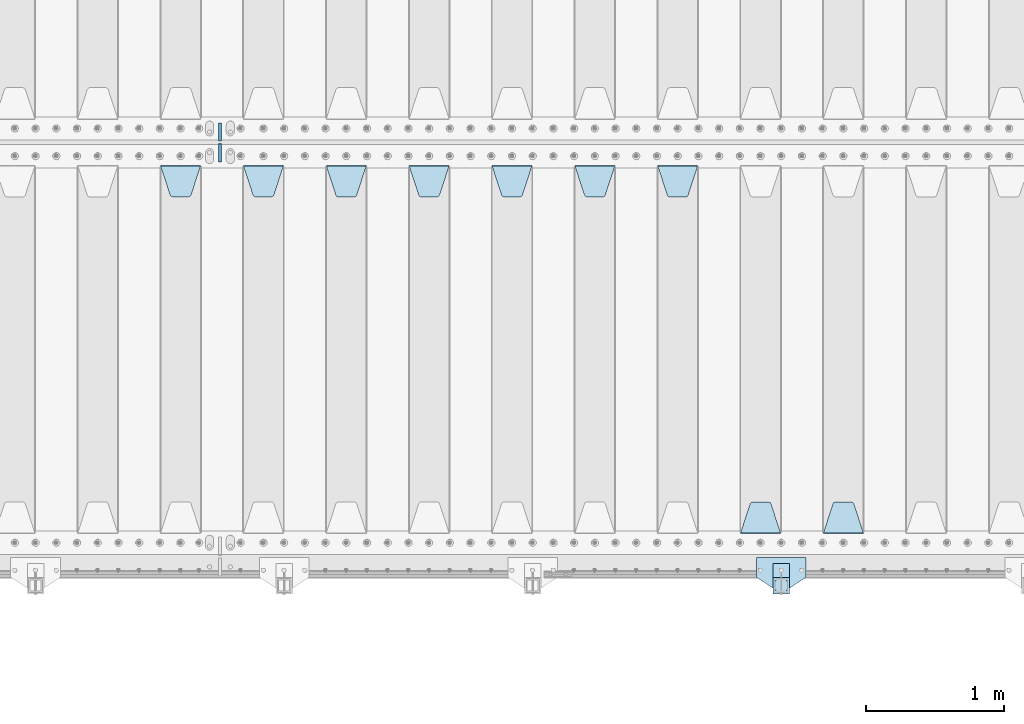
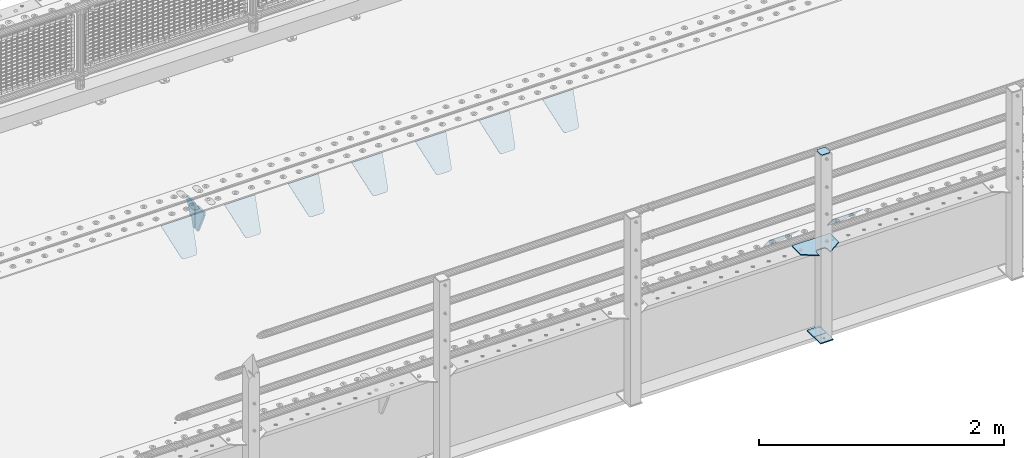
# One storey, part 206 of 242: 15 plates.
"""IFC2X3 building model written with IfcOpenShell, lengths in millimetres."""

import ifcopenshell
import ifcopenshell.guid

model = None  # the IFC model being written
_history = None  # IfcOwnerHistory: only IFC2X3 demands one
_inside = {}  # id of a spatial element -> (the spatial element, [elements in it])
_under = {}  # id of a project, library or spatial element -> (it, [spatial elements below it])
_declared = {}  # id of a project -> (the project, [libraries it declares])
_typed = {}  # id of a type object -> (the type object, [elements of that type])
_made_of = {}  # id of a material, layer set ... -> (it, [elements and type objects made of it])


def new_model(schema):
    """Start an empty IFC model of exactly this schema.

    Asked for "IFC4X3", IfcOpenShell would pick the latest addendum, in which some entities
    have other attributes; the version numbers below select the first issue.
    IFC2X3 requires an IfcOwnerHistory on every rooted entity: one is made here for all.
    """
    global model, _history
    if schema == "IFC4X3":
        model = ifcopenshell.file(schema_version=(4, 3, 0, 0))
    else:
        model = ifcopenshell.file(schema=schema)
    _inside.clear()
    _under.clear()
    _declared.clear()
    _typed.clear()
    _made_of.clear()
    _history = None
    if model.schema == "IFC2X3":
        org = make("IfcOrganization", Name="unknown")
        user = make(
            "IfcPersonAndOrganization",
            ThePerson=make("IfcPerson", FamilyName="unknown"),
            TheOrganization=org,
        )
        app = make(
            "IfcApplication",
            ApplicationDeveloper=org,
            Version="unknown",
            ApplicationFullName="unknown",
            ApplicationIdentifier="unknown",
        )
        _history = make(
            "IfcOwnerHistory",
            OwningUser=user,
            OwningApplication=app,
            ChangeAction="ADDED",
            CreationDate=0,
        )
    return model


def make(cls, **values):
    """One entity of the class cls with the attributes given. An attribute that is None is left unset."""
    return model.create_entity(
        cls, **{name: value for name, value in values.items() if value is not None}
    )


def rooted(cls, **values):
    """An entity with a GlobalId (a new one), such as an element, a storey or a relation."""
    return make(cls, GlobalId=ifcopenshell.guid.new(), OwnerHistory=_history, **values)


def si_unit(unit_type, name, prefix=None):
    """IfcSIUnit, for example si_unit("LENGTHUNIT", "METRE", prefix="MILLI")."""
    return make("IfcSIUnit", UnitType=unit_type, Prefix=prefix, Name=name)


def assignment(units):
    """IfcUnitAssignment: the units of a project."""
    return None if units is None else make("IfcUnitAssignment", Units=units)


def point(xyz):
    """IfcCartesianPoint."""
    return None if xyz is None else make("IfcCartesianPoint", Coordinates=xyz)


def direction(xyz):
    """IfcDirection."""
    return None if xyz is None else make("IfcDirection", DirectionRatios=xyz)


def frame(location, z_axis=None, x_axis=None):
    """IfcAxis2Placement3D, a coordinate frame: its origin and axes. An axis left out is left unset."""
    return make(
        "IfcAxis2Placement3D",
        Location=point(location),
        Axis=direction(z_axis),
        RefDirection=direction(x_axis),
    )


def origin_with_axes():
    """The frame at (0, 0, 0) with the z axis (0, 0, 1) and the x axis (1, 0, 0) written out."""
    return frame((0.0, 0.0, 0.0), z_axis=(0.0, 0.0, 1.0), x_axis=(1.0, 0.0, 0.0))


def place(relative_to, where):
    """IfcLocalPlacement: puts the frame where relative to a parent placement (None: the world)."""
    return make(
        "IfcLocalPlacement", PlacementRelTo=relative_to, RelativePlacement=where
    )


def context(
    kind, dimensions, precision=None, world=None, true_north=None, identifier=None
):
    """IfcGeometricRepresentationContext, for example the 3D "Model" context."""
    return make(
        "IfcGeometricRepresentationContext",
        ContextIdentifier=identifier,
        ContextType=kind,
        CoordinateSpaceDimension=dimensions,
        Precision=precision,
        WorldCoordinateSystem=world,
        TrueNorth=true_north,
    )


def subcontext(parent, identifier, kind, view, scale=None):
    """IfcGeometricRepresentationSubContext, for example "Body" below "Model"."""
    return make(
        "IfcGeometricRepresentationSubContext",
        ContextIdentifier=identifier,
        ContextType=kind,
        ParentContext=parent,
        TargetScale=scale,
        TargetView=view,
    )


def project(units=None, contexts=None):
    """IfcProject with its units and contexts."""
    return rooted(
        "IfcProject",
        Name="project",
        RepresentationContexts=contexts,
        UnitsInContext=assignment(units),
    )


def spatial(cls, under=None, at=None, **own):
    """A site, building, storey or space (cls), placed at a placement, below another one or the project."""
    s = rooted(cls, ObjectPlacement=at, **own)
    if under is not None:
        _under.setdefault(under.id(), (under, []))[1].append(s)
    return s


def faces_of(points, faces, orient=None, outer=None):
    """IfcFace entities. A face is a list of loops; a loop is a list of indices into points, from 0.

    orient and outer hold one flag for each loop. By default every Orientation is true, the
    first loop of a face is its IfcFaceOuterBound and the others are IfcFaceBound.
    """
    made = []
    for i, loops in enumerate(faces):
        bounds = []
        for j, loop in enumerate(loops):
            is_outer = j == 0 if outer is None else outer[i][j]
            bounds.append(
                make(
                    "IfcFaceOuterBound" if is_outer else "IfcFaceBound",
                    Bound=make("IfcPolyLoop", Polygon=[points[k] for k in loop]),
                    Orientation=True if orient is None else orient[i][j],
                )
            )
        made.append(make("IfcFace", Bounds=bounds))
    return made


def faceted_brep(points, faces, orient=None, outer=None, voids=None):
    """IfcFacetedBrep: a solid bounded by flat faces; with voids (closed shells), ...WithVoids."""
    shared = [point(p) for p in points]
    hull = make("IfcClosedShell", CfsFaces=faces_of(shared, faces, orient, outer))
    if voids is None:
        return make("IfcFacetedBrep", Outer=hull)
    return make(
        "IfcFacetedBrepWithVoids",
        Outer=hull,
        Voids=[
            make(cls, CfsFaces=faces_of(shared, fs, o, b)) for cls, fs, o, b in voids
        ],
    )


def shape(context_of_items, identifier, shape_type, items):
    """IfcShapeRepresentation: the items that make up one representation, for example the "Body"."""
    return make(
        "IfcShapeRepresentation",
        ContextOfItems=context_of_items,
        RepresentationIdentifier=identifier,
        RepresentationType=shape_type,
        Items=items,
    )


def material(Name=None, Category=None):
    """IfcMaterial."""
    return make("IfcMaterial", Name=Name, Category=Category)


def made_of(thing, what):
    """Note that an element or type object is made of a material, layer set ...; save() writes the relation."""
    if what is not None:
        _made_of.setdefault(what.id(), (what, []))[1].append(thing)
    return thing


def type_object(cls, material=None, **own):
    """A type object (cls), such as IfcWallType, which elements share."""
    return made_of(rooted(cls, **own), material)


def element(
    cls,
    number,
    at=None,
    inside=None,
    cuts=None,
    type_object=None,
    material=None,
    context=None,
    identifier="Body",
    shape_type=None,
    held_by="IfcProductDefinitionShape",
    body=None,
    shapes=None,
    **own,
):
    """One element of the class cls, such as IfcWall. Its Tag is "e" and its number.

    at: its placement. inside: the storey or other place that contains it. cuts: it is an
    opening in that element (IfcRelVoidsElement). A single representation is given by context,
    identifier, shape_type and body (its items); several are given by shapes. held_by: the class
    of the entity that holds the representations. save() writes the other relations.
    """
    e = rooted(cls, Tag="e%d" % number, ObjectPlacement=at, **own)
    if body is not None:
        shapes = [shape(context, identifier, shape_type, body)]
    if shapes is not None:
        e.Representation = make(held_by, Representations=shapes)
    if inside is not None:
        _inside.setdefault(inside.id(), (inside, []))[1].append(e)
    if cuts is not None:
        rooted(
            "IfcRelVoidsElement", RelatingBuildingElement=cuts, RelatedOpeningElement=e
        )
    if type_object is not None:
        _typed.setdefault(type_object.id(), (type_object, []))[1].append(e)
    return made_of(e, material)


def aggregate(whole, parts):
    """IfcRelAggregates: a whole, such as a stair, and the parts it consists of."""
    return rooted("IfcRelAggregates", RelatingObject=whole, RelatedObjects=parts)


def save(model, path):
    """Write the relations noted so far, then the file.

    IfcRelAggregates (storeys below a building ...), IfcRelContainedInSpatialStructure (elements
    in a storey), IfcRelDefinesByType, IfcRelAssociatesMaterial and IfcRelDeclares: one each for
    every whole, place, type object, material and project.
    """
    for whole, parts in _under.values():
        aggregate(whole, parts)
    for where, things in _inside.values():
        rooted(
            "IfcRelContainedInSpatialStructure",
            RelatedElements=things,
            RelatingStructure=where,
        )
    for kind, things in _typed.values():
        rooted("IfcRelDefinesByType", RelatedObjects=things, RelatingType=kind)
    for what, things in _made_of.values():
        rooted("IfcRelAssociatesMaterial", RelatedObjects=things, RelatingMaterial=what)
    for by, libraries in _declared.values():
        rooted("IfcRelDeclares", RelatingContext=by, RelatedDefinitions=libraries)
    model.write(path)


model = new_model("IFC2X3")

# Units and contexts
model_context = context("Model", 3, precision=1e-05, world=origin_with_axes())
body_context = subcontext(model_context, "Body", "Model", "MODEL_VIEW")
ifc_project = project(units=[si_unit("LENGTHUNIT", "METRE", prefix="MILLI"), si_unit("AREAUNIT", "SQUARE_METRE"), si_unit("VOLUMEUNIT", "CUBIC_METRE"), si_unit("MASSUNIT", "GRAM", prefix="KILO"), si_unit("TIMEUNIT", "SECOND"), si_unit("PLANEANGLEUNIT", "RADIAN"), si_unit("SOLIDANGLEUNIT", "STERADIAN"), si_unit("THERMODYNAMICTEMPERATUREUNIT", "DEGREE_CELSIUS"), si_unit("LUMINOUSINTENSITYUNIT", "LUMEN")], contexts=[model_context])

# Site, building, storey
site_placement = place(None, origin_with_axes())
site = spatial("IfcSite", under=ifc_project, at=site_placement, CompositionType="ELEMENT")
building_placement = place(site_placement, origin_with_axes())
building = spatial("IfcBuilding", under=site, at=building_placement, Name="Standard", CompositionType="ELEMENT")
storey_placement = place(building_placement, origin_with_axes())
storey = spatial("IfcBuildingStorey", under=building, at=storey_placement, Name="Undefined", CompositionType="ELEMENT", Elevation=0.0)

# Plates
ifc_material_1 = material(Name="STEEL/S355J2")
plate_type_1 = type_object("IfcPlateType", PredefinedType="NOTDEFINED")
plate_1_placement = place(storey_placement, frame((-30920.0, -24005.0, 5.00000000004911), z_axis=(0.0, -1.0, 0.0), x_axis=(-1.0, 0.0, 0.0)))
element("IfcPlate", 1, at=plate_1_placement, inside=storey, type_object=plate_type_1, material=ifc_material_1, context=body_context, shape_type="Brep", body=[
    faceted_brep([(0.0, -5.0, 0.0), (2.31396552408114e-06, -5.0, 145.0), (2.31396552408114e-06, 5.0, 145.0), (0.0, 5.0, 0.0), (130.0, -5.0, 230.0), (130.0, 5.0, 230.0), (130.0, -5.0, 180.0), (130.0, 5.0, 180.0), (130.48036798992, -5.0, 175.122741949595), (130.48036798992, 5.0, 175.122741949595), (131.903011687216, -5.0, 170.432914190871), (131.903011687216, 5.0, 170.432914190871), (134.213259692435, -5.0, 166.110744174512), (134.213259692435, 5.0, 166.110744174512), (137.322330470335, -5.0, 162.322330470335), (137.322330470335, 5.0, 162.322330470335), (141.110744174512, -5.0, 159.213259692435), (141.110744174512, 5.0, 159.213259692435), (145.432914190871, -5.0, 156.903011687216), (145.432914190871, 5.0, 156.903011687216), (150.122741949595, -5.0, 155.48036798992), (150.122741949595, 5.0, 155.48036798992), (155.0, -5.0, 155.0), (155.0, 5.0, 155.0), (205.0, -5.0, 155.0), (205.0, 5.0, 155.0), (209.877258050405, -5.0, 155.48036798992), (209.877258050405, 5.0, 155.48036798992), (214.567085809129, -5.0, 156.903011687216), (214.567085809129, 5.0, 156.903011687216), (218.889255825488, -5.0, 159.213259692435), (218.889255825488, 5.0, 159.213259692435), (222.677669529665, -5.0, 162.322330470335), (222.677669529665, 5.0, 162.322330470335), (225.786740307565, -5.0, 166.110744174512), (225.786740307565, 5.0, 166.110744174512), (228.096988312784, -5.0, 170.432914190871), (228.096988312784, 5.0, 170.432914190871), (229.51963201008, -5.0, 175.122741949595), (229.51963201008, 5.0, 175.122741949595), (230.0, -5.0, 180.0), (230.0, 5.0, 180.0), (230.0, -5.0, 230.0), (230.0, 5.0, 230.0), (360.0, -5.0, 145.0), (360.0, 5.0, 145.0), (360.0, -5.0, -7.27595761418343e-12), (360.0, 5.0, -7.27595761418343e-12)], [[[0, 1, 2, 3]], [[1, 4, 5, 2]], [[4, 6, 7, 5]], [[6, 8, 9, 7]], [[8, 10, 11, 9]], [[10, 12, 13, 11]], [[12, 14, 15, 13]], [[14, 16, 17, 15]], [[16, 18, 19, 17]], [[18, 20, 21, 19]], [[20, 22, 23, 21]], [[22, 24, 25, 23]], [[24, 26, 27, 25]], [[26, 28, 29, 27]], [[28, 30, 31, 29]], [[30, 32, 33, 31]], [[32, 34, 35, 33]], [[34, 36, 37, 35]], [[36, 38, 39, 37]], [[38, 40, 41, 39]], [[40, 42, 43, 41]], [[42, 44, 45, 43]], [[44, 46, 47, 45]], [[46, 0, 3, 47]], [[5, 7, 9, 11, 13, 15, 17, 19, 21, 23, 25, 27, 29, 31, 33, 35, 37, 39, 41, 43, 45, 47, 3, 2]], [[46, 44, 42, 40, 38, 36, 34, 32, 30, 28, 26, 24, 22, 20, 18, 16, 14, 12, 10, 8, 6, 4, 1, 0]]]),
])
plate_type_2 = type_object("IfcPlateType", PredefinedType="NOTDEFINED")
plate_2_placement = place(storey_placement, frame((-31040.0000000001, -24050.0000000002, -850.000000000002), z_axis=(0.0, -1.0, 0.0), x_axis=(-1.0, 0.0, 0.0)))
element("IfcPlate", 2, at=plate_2_placement, inside=storey, type_object=plate_type_2, material=ifc_material_1, context=body_context, shape_type="Brep", body=[
    faceted_brep([(53.6360389691836, -5.0, 176.363961030471), (53.6360389691836, 5.0, 176.363961030471), (59.9999999998618, 5.0, 178.999999999793), (59.9999999998618, -5.0, 178.999999999793), (66.3639610305399, 5.0, 176.363961030471), (66.3639610305399, -5.0, 176.363961030471), (68.9999999998618, 5.0, 169.999999999793), (68.9999999998618, -5.0, 169.999999999793), (66.3639610305399, 5.0, 163.636038969114), (66.3639610305399, -5.0, 163.636038969114), (59.9999999998618, 5.0, 160.999999999793), (59.9999999998618, -5.0, 160.999999999793), (53.6360389691836, 5.0, 163.636038969114), (53.6360389691836, -5.0, 163.636038969114), (50.9999999998618, 5.0, 169.999999999793), (50.9999999998618, -5.0, 169.999999999793), (120.0, -5.0, 0.0), (120.0, -5.0, 220.0), (0.0, -5.0, 220.0), (0.0, -5.0, 0.0), (0.0, 5.0, 0.0), (120.0, 5.0, 0.0), (120.0, 5.0, 220.0), (0.0, 5.0, 220.0)], [[[0, 1, 2, 3]], [[3, 2, 4, 5]], [[5, 4, 6, 7]], [[7, 6, 8, 9]], [[9, 8, 10, 11]], [[11, 10, 12, 13]], [[13, 12, 14, 15]], [[15, 14, 1, 0]], [[16, 17, 18, 19], [3, 5, 7, 9, 11, 13, 15, 0]], [[16, 19, 20, 21]], [[17, 16, 21, 22]], [[18, 17, 22, 23]], [[19, 18, 23, 20]], [[22, 21, 20, 23], [10, 8, 6, 4, 2, 1, 14, 12]]]),
])
plate_type_3 = type_object("IfcPlateType", PredefinedType="NOTDEFINED")
plate_3_placement = place(storey_placement, frame((-31144.0000000001, -24166.0000000002, 1012.50000000001), z_axis=(0.0, -1.0, 0.0), x_axis=(1.0, 0.0, 0.0)))
element("IfcPlate", 3, at=plate_3_placement, inside=storey, type_object=plate_type_3, material=ifc_material_1, context=body_context, shape_type="Brep", body=[
    faceted_brep([(0.0, -2.5, 19.0), (0.0, -2.5, 69.0), (0.0, 2.5, 69.0), (0.0, 2.5, 19.0), (0.476369668544066, -2.5, 73.2278977451715), (0.476369668544066, 2.5, 73.2278977451715), (1.88159150985302, -2.5, 77.2437910432345), (1.88159150985302, 2.5, 77.2437910432345), (4.14520183310742, -2.5, 80.8463062353148), (4.14520183310742, 2.5, 80.8463062353148), (7.15369376468516, -2.5, 83.8547981668926), (7.15369376468516, 2.5, 83.8547981668926), (10.7562089567655, -2.5, 86.118408490147), (10.7562089567655, 2.5, 86.118408490147), (14.7721022548285, -2.5, 87.5236303314559), (14.7721022548285, 2.5, 87.5236303314559), (19.0, -2.5, 88.0), (19.0, 2.5, 88.0), (69.0, -2.5, 88.0), (69.0, 2.5, 88.0), (73.2278977451715, -2.5, 87.5236303314559), (73.2278977451715, 2.5, 87.5236303314559), (77.2437910432345, -2.5, 86.118408490147), (77.2437910432345, 2.5, 86.118408490147), (80.8463062353148, -2.5, 83.8547981668926), (80.8463062353148, 2.5, 83.8547981668926), (83.8547981668926, -2.5, 80.8463062353148), (83.8547981668926, 2.5, 80.8463062353148), (86.118408490147, -2.5, 77.2437910432345), (86.118408490147, 2.5, 77.2437910432345), (87.5236303314559, -2.5, 73.2278977451715), (87.5236303314559, 2.5, 73.2278977451715), (88.0, -2.5, 69.0), (88.0, 2.5, 69.0), (88.0, -2.5, 19.0), (88.0, 2.5, 19.0), (87.5236303314559, -2.5, 14.7721022548285), (87.5236303314559, 2.5, 14.7721022548285), (86.118408490147, -2.5, 10.7562089567655), (86.118408490147, 2.5, 10.7562089567655), (83.8547981668926, -2.5, 7.15369376468516), (83.8547981668926, 2.5, 7.15369376468516), (80.8463062353148, -2.5, 4.14520183310742), (80.8463062353148, 2.5, 4.14520183310742), (77.2437910432345, -2.5, 1.88159150985302), (77.2437910432345, 2.5, 1.88159150985302), (73.2278977451715, -2.5, 0.476369668544066), (73.2278977451715, 2.5, 0.476369668544066), (69.0, -2.5, 0.0), (69.0, 2.5, 0.0), (19.0, -2.5, 0.0), (19.0, 2.5, 0.0), (14.7721022548285, -2.5, 0.476369668544066), (14.7721022548285, 2.5, 0.476369668544066), (10.7562089567655, -2.5, 1.88159150985302), (10.7562089567655, 2.5, 1.88159150985302), (7.15369376468516, -2.5, 4.14520183310742), (7.15369376468516, 2.5, 4.14520183310742), (4.14520183310742, -2.5, 7.15369376468516), (4.14520183310742, 2.5, 7.15369376468516), (1.88159150985302, -2.5, 10.7562089567655), (1.88159150985302, 2.5, 10.7562089567655), (0.476369668544066, -2.5, 14.7721022548285), (0.476369668544066, 2.5, 14.7721022548285)], [[[0, 1, 2, 3]], [[1, 4, 5, 2]], [[4, 6, 7, 5]], [[6, 8, 9, 7]], [[8, 10, 11, 9]], [[10, 12, 13, 11]], [[12, 14, 15, 13]], [[14, 16, 17, 15]], [[16, 18, 19, 17]], [[18, 20, 21, 19]], [[20, 22, 23, 21]], [[22, 24, 25, 23]], [[24, 26, 27, 25]], [[26, 28, 29, 27]], [[28, 30, 31, 29]], [[30, 32, 33, 31]], [[32, 34, 35, 33]], [[34, 36, 37, 35]], [[36, 38, 39, 37]], [[38, 40, 41, 39]], [[40, 42, 43, 41]], [[42, 44, 45, 43]], [[44, 46, 47, 45]], [[46, 48, 49, 47]], [[48, 50, 51, 49]], [[50, 52, 53, 51]], [[52, 54, 55, 53]], [[54, 56, 57, 55]], [[56, 58, 59, 57]], [[58, 60, 61, 59]], [[60, 62, 63, 61]], [[62, 0, 3, 63]], [[5, 7, 9, 11, 13, 15, 17, 19, 21, 23, 25, 27, 29, 31, 33, 35, 37, 39, 41, 43, 45, 47, 49, 51, 53, 55, 57, 59, 61, 63, 3, 2]], [[62, 60, 58, 56, 54, 52, 50, 48, 46, 44, 42, 40, 38, 36, 34, 32, 30, 28, 26, 24, 22, 20, 18, 16, 14, 12, 10, 8, 6, 4, 1, 0]]]),
])
plate_type_4 = type_object("IfcPlateType", PredefinedType="NOTDEFINED")
plate_4_placement = place(storey_placement, frame((-31040.0000000001, -24050.0000000002, -857.500000000002), z_axis=(0.0, -1.0, 0.0), x_axis=(-1.0, 0.0, 0.0)))
element("IfcPlate", 4, at=plate_4_placement, inside=storey, type_object=plate_type_4, material=ifc_material_1, context=body_context, shape_type="Brep", body=[
    faceted_brep([(0.0, -2.5, 0.0), (0.0, -2.5, 100.0), (0.0, 2.5, 100.0), (0.0, 2.5, 0.0), (120.0, -2.5, 100.0), (120.0, 2.5, 100.0), (120.0, -2.5, 0.0), (120.0, 2.5, 0.0)], [[[0, 1, 2, 3]], [[1, 4, 5, 2]], [[4, 6, 7, 5]], [[6, 0, 3, 7]], [[5, 7, 3, 2]], [[6, 4, 1, 0]]]),
])
ifc_material_2 = material(Name="STEEL/S355N")
plate_type_5 = type_object("IfcPlateType", PredefinedType="NOTDEFINED")
plate_5_placement = place(storey_placement, frame((-30505.0, -23831.767766953, -1.76776695296758), z_axis=(0.0, 0.707106781186547, -0.707106781186548), x_axis=(-1.0, 0.0, 0.0)))
element("IfcPlate", 5, at=plate_5_placement, inside=storey, type_object=plate_type_5, material=ifc_material_2, context=body_context, shape_type="Brep", body=[
    faceted_brep([(0.0, -2.5, 0.0), (69.345504679477, -2.50000000000182, 300.171731424829), (69.345504679477, 2.5, 300.171731424829), (0.0, 2.5, 0.0), (70.9274061199576, -2.5, 304.897442415398), (70.9274061199576, 2.5, 304.897442415398), (73.3818627772307, -2.5, 309.234538108525), (73.3818627772307, 2.50000000000182, 309.234538108529), (76.6187032999551, -2.5, 313.023683126101), (76.6187032999551, 2.50000000000182, 313.023683126103), (80.5190132704993, -2.5, 316.12567259537), (80.5190132704993, 2.5, 316.12567259537), (84.9395038596849, -2.5, 318.426546230474), (84.9395038596849, 2.50000000000182, 318.426546230476), (89.7177759439219, -2.49999999999818, 319.841774983273), (89.7177759439219, 2.50000000000182, 319.841774983273), (94.678286292652, -2.5, 320.319366455076), (94.678286292652, 2.5, 320.319366455076), (195.321713707348, -2.5, 320.319366455076), (195.321713707348, 2.5, 320.319366455076), (200.282224056078, -2.5, 319.841774983272), (200.282224056078, 2.50000000000182, 319.841774983273), (205.060496140315, -2.5, 318.426546230474), (205.060496140315, 2.49999999999818, 318.426546230474), (209.480986729501, -2.49999999999818, 316.12567259537), (209.480986729501, 2.5, 316.12567259537), (213.381296700045, -2.5, 313.023683126101), (213.381296700045, 2.49999999999818, 313.023683126101), (216.618137222769, -2.5, 309.234538108525), (216.618137222769, 2.5, 309.234538108523), (219.072593880042, -2.49999999999818, 304.897442415398), (219.072593880042, 2.50000000000182, 304.897442415398), (220.654495320523, -2.50000000000182, 300.171731424829), (220.654495320523, 2.5, 300.171731424829), (290.0, -2.5, 0.0), (290.0, 2.5, -1.81898940354586e-12)], [[[0, 1, 2, 3]], [[1, 4, 5, 2]], [[4, 6, 7, 5]], [[6, 8, 9, 7]], [[8, 10, 11, 9]], [[10, 12, 13, 11]], [[12, 14, 15, 13]], [[14, 16, 17, 15]], [[16, 18, 19, 17]], [[18, 20, 21, 19]], [[20, 22, 23, 21]], [[22, 24, 25, 23]], [[24, 26, 27, 25]], [[26, 28, 29, 27]], [[28, 30, 31, 29]], [[30, 32, 33, 31]], [[32, 34, 35, 33]], [[34, 0, 3, 35]], [[5, 7, 9, 11, 13, 15, 17, 19, 21, 23, 25, 27, 29, 31, 33, 35, 3, 2]], [[34, 32, 30, 28, 26, 24, 22, 20, 18, 16, 14, 12, 10, 8, 6, 4, 1, 0]]]),
])
plate_6_placement = place(storey_placement, frame((-31105.0, -23831.767766953, -1.76776695296758), z_axis=(0.0, 0.707106781186547, -0.707106781186548), x_axis=(-1.0, 0.0, 0.0)))
element("IfcPlate", 6, at=plate_6_placement, inside=storey, type_object=plate_type_5, material=ifc_material_2, context=body_context, shape_type="Brep", body=[
    faceted_brep([(0.0, -2.5, 0.0), (69.345504679477, -2.50000000000182, 300.171731424829), (69.345504679477, 2.5, 300.171731424829), (0.0, 2.5, 0.0), (70.9274061199576, -2.5, 304.897442415398), (70.9274061199576, 2.5, 304.897442415398), (73.3818627772307, -2.5, 309.234538108525), (73.3818627772307, 2.50000000000182, 309.234538108529), (76.6187032999551, -2.5, 313.023683126101), (76.6187032999551, 2.50000000000182, 313.023683126103), (80.5190132704993, -2.5, 316.12567259537), (80.5190132704993, 2.5, 316.12567259537), (84.9395038596849, -2.5, 318.426546230474), (84.9395038596849, 2.50000000000182, 318.426546230476), (89.7177759439219, -2.49999999999818, 319.841774983273), (89.7177759439219, 2.50000000000182, 319.841774983273), (94.678286292652, -2.5, 320.319366455076), (94.678286292652, 2.5, 320.319366455076), (195.321713707348, -2.5, 320.319366455076), (195.321713707348, 2.5, 320.319366455076), (200.282224056078, -2.5, 319.841774983272), (200.282224056078, 2.50000000000182, 319.841774983273), (205.060496140315, -2.5, 318.426546230474), (205.060496140315, 2.49999999999818, 318.426546230474), (209.480986729501, -2.49999999999818, 316.12567259537), (209.480986729501, 2.5, 316.12567259537), (213.381296700045, -2.5, 313.023683126101), (213.381296700045, 2.49999999999818, 313.023683126101), (216.618137222769, -2.5, 309.234538108525), (216.618137222769, 2.5, 309.234538108523), (219.072593880042, -2.49999999999818, 304.897442415398), (219.072593880042, 2.50000000000182, 304.897442415398), (220.654495320523, -2.50000000000182, 300.171731424829), (220.654495320523, 2.5, 300.171731424829), (290.0, -2.5, 0.0), (290.0, 2.5, -1.81898940354586e-12)], [[[0, 1, 2, 3]], [[1, 4, 5, 2]], [[4, 6, 7, 5]], [[6, 8, 9, 7]], [[8, 10, 11, 9]], [[10, 12, 13, 11]], [[12, 14, 15, 13]], [[14, 16, 17, 15]], [[16, 18, 19, 17]], [[18, 20, 21, 19]], [[20, 22, 23, 21]], [[22, 24, 25, 23]], [[24, 26, 27, 25]], [[26, 28, 29, 27]], [[28, 30, 31, 29]], [[30, 32, 33, 31]], [[32, 34, 35, 33]], [[34, 0, 3, 35]], [[5, 7, 9, 11, 13, 15, 17, 19, 21, 23, 25, 27, 29, 31, 33, 35, 3, 2]], [[34, 32, 30, 28, 26, 24, 22, 20, 18, 16, 14, 12, 10, 8, 6, 4, 1, 0]]]),
])
plate_7_placement = place(storey_placement, frame((-31995.0, -21168.232233044, -1.76776695296576), z_axis=(0.0, -0.707106781186547, -0.707106781186548), x_axis=(1.0, 0.0, 0.0)))
element("IfcPlate", 7, at=plate_7_placement, inside=storey, type_object=plate_type_5, material=ifc_material_2, context=body_context, shape_type="Brep", body=[
    faceted_brep([(0.0, -2.5, 0.0), (69.345504679477, -2.50000000000182, 300.171731424829), (69.345504679477, 2.5, 300.171731424829), (0.0, 2.5, 0.0), (70.9274061199576, -2.5, 304.897442415398), (70.9274061199576, 2.5, 304.897442415398), (73.3818627772307, -2.5, 309.234538108525), (73.3818627772307, 2.50000000000182, 309.234538108529), (76.6187032999551, -2.5, 313.023683126101), (76.6187032999551, 2.50000000000182, 313.023683126103), (80.5190132704993, -2.5, 316.12567259537), (80.5190132704993, 2.5, 316.12567259537), (84.9395038596849, -2.5, 318.426546230474), (84.9395038596849, 2.50000000000182, 318.426546230476), (89.7177759439219, -2.49999999999818, 319.841774983273), (89.7177759439219, 2.50000000000182, 319.841774983273), (94.678286292652, -2.5, 320.319366455076), (94.678286292652, 2.5, 320.319366455076), (195.321713707348, -2.5, 320.319366455076), (195.321713707348, 2.5, 320.319366455076), (200.282224056078, -2.5, 319.841774983272), (200.282224056078, 2.50000000000182, 319.841774983273), (205.060496140315, -2.5, 318.426546230474), (205.060496140315, 2.49999999999818, 318.426546230474), (209.480986729501, -2.49999999999818, 316.12567259537), (209.480986729501, 2.5, 316.12567259537), (213.381296700045, -2.5, 313.023683126101), (213.381296700045, 2.49999999999818, 313.023683126101), (216.618137222769, -2.5, 309.234538108525), (216.618137222769, 2.5, 309.234538108523), (219.072593880042, -2.49999999999818, 304.897442415398), (219.072593880042, 2.50000000000182, 304.897442415398), (220.654495320523, -2.50000000000182, 300.171731424829), (220.654495320523, 2.5, 300.171731424829), (290.0, -2.5, 0.0), (290.0, 2.5, -1.81898940354586e-12)], [[[0, 1, 2, 3]], [[1, 4, 5, 2]], [[4, 6, 7, 5]], [[6, 8, 9, 7]], [[8, 10, 11, 9]], [[10, 12, 13, 11]], [[12, 14, 15, 13]], [[14, 16, 17, 15]], [[16, 18, 19, 17]], [[18, 20, 21, 19]], [[20, 22, 23, 21]], [[22, 24, 25, 23]], [[24, 26, 27, 25]], [[26, 28, 29, 27]], [[28, 30, 31, 29]], [[30, 32, 33, 31]], [[32, 34, 35, 33]], [[34, 0, 3, 35]], [[5, 7, 9, 11, 13, 15, 17, 19, 21, 23, 25, 27, 29, 31, 33, 35, 3, 2]], [[34, 32, 30, 28, 26, 24, 22, 20, 18, 16, 14, 12, 10, 8, 6, 4, 1, 0]]]),
])
plate_8_placement = place(storey_placement, frame((-32595.0, -21168.232233044, -1.76776695296576), z_axis=(0.0, -0.707106781186547, -0.707106781186548), x_axis=(1.0, 0.0, 0.0)))
element("IfcPlate", 8, at=plate_8_placement, inside=storey, type_object=plate_type_5, material=ifc_material_2, context=body_context, shape_type="Brep", body=[
    faceted_brep([(0.0, -2.5, 0.0), (69.345504679477, -2.50000000000182, 300.171731424829), (69.345504679477, 2.5, 300.171731424829), (0.0, 2.5, 0.0), (70.9274061199576, -2.5, 304.897442415398), (70.9274061199576, 2.5, 304.897442415398), (73.3818627772307, -2.5, 309.234538108525), (73.3818627772307, 2.50000000000182, 309.234538108529), (76.6187032999551, -2.5, 313.023683126101), (76.6187032999551, 2.50000000000182, 313.023683126103), (80.5190132704993, -2.5, 316.12567259537), (80.5190132704993, 2.5, 316.12567259537), (84.9395038596849, -2.5, 318.426546230474), (84.9395038596849, 2.50000000000182, 318.426546230476), (89.7177759439219, -2.49999999999818, 319.841774983273), (89.7177759439219, 2.50000000000182, 319.841774983273), (94.678286292652, -2.5, 320.319366455076), (94.678286292652, 2.5, 320.319366455076), (195.321713707348, -2.5, 320.319366455076), (195.321713707348, 2.5, 320.319366455076), (200.282224056078, -2.5, 319.841774983272), (200.282224056078, 2.50000000000182, 319.841774983273), (205.060496140315, -2.5, 318.426546230474), (205.060496140315, 2.49999999999818, 318.426546230474), (209.480986729501, -2.49999999999818, 316.12567259537), (209.480986729501, 2.5, 316.12567259537), (213.381296700045, -2.5, 313.023683126101), (213.381296700045, 2.49999999999818, 313.023683126101), (216.618137222769, -2.5, 309.234538108525), (216.618137222769, 2.5, 309.234538108523), (219.072593880042, -2.49999999999818, 304.897442415398), (219.072593880042, 2.50000000000182, 304.897442415398), (220.654495320523, -2.50000000000182, 300.171731424829), (220.654495320523, 2.5, 300.171731424829), (290.0, -2.5, 0.0), (290.0, 2.5, -1.81898940354586e-12)], [[[0, 1, 2, 3]], [[1, 4, 5, 2]], [[4, 6, 7, 5]], [[6, 8, 9, 7]], [[8, 10, 11, 9]], [[10, 12, 13, 11]], [[12, 14, 15, 13]], [[14, 16, 17, 15]], [[16, 18, 19, 17]], [[18, 20, 21, 19]], [[20, 22, 23, 21]], [[22, 24, 25, 23]], [[24, 26, 27, 25]], [[26, 28, 29, 27]], [[28, 30, 31, 29]], [[30, 32, 33, 31]], [[32, 34, 35, 33]], [[34, 0, 3, 35]], [[5, 7, 9, 11, 13, 15, 17, 19, 21, 23, 25, 27, 29, 31, 33, 35, 3, 2]], [[34, 32, 30, 28, 26, 24, 22, 20, 18, 16, 14, 12, 10, 8, 6, 4, 1, 0]]]),
])
plate_9_placement = place(storey_placement, frame((-33195.0, -21168.232233044, -1.76776695296576), z_axis=(0.0, -0.707106781186547, -0.707106781186548), x_axis=(1.0, 0.0, 0.0)))
element("IfcPlate", 9, at=plate_9_placement, inside=storey, type_object=plate_type_5, material=ifc_material_2, context=body_context, shape_type="Brep", body=[
    faceted_brep([(0.0, -2.5, 0.0), (69.345504679477, -2.50000000000182, 300.171731424829), (69.345504679477, 2.5, 300.171731424829), (0.0, 2.5, 0.0), (70.9274061199576, -2.5, 304.897442415398), (70.9274061199576, 2.5, 304.897442415398), (73.3818627772307, -2.5, 309.234538108525), (73.3818627772307, 2.50000000000182, 309.234538108529), (76.6187032999551, -2.5, 313.023683126101), (76.6187032999551, 2.50000000000182, 313.023683126103), (80.5190132704993, -2.5, 316.12567259537), (80.5190132704993, 2.5, 316.12567259537), (84.9395038596849, -2.5, 318.426546230474), (84.9395038596849, 2.50000000000182, 318.426546230476), (89.7177759439219, -2.49999999999818, 319.841774983273), (89.7177759439219, 2.50000000000182, 319.841774983273), (94.678286292652, -2.5, 320.319366455076), (94.678286292652, 2.5, 320.319366455076), (195.321713707348, -2.5, 320.319366455076), (195.321713707348, 2.5, 320.319366455076), (200.282224056078, -2.5, 319.841774983272), (200.282224056078, 2.50000000000182, 319.841774983273), (205.060496140315, -2.5, 318.426546230474), (205.060496140315, 2.49999999999818, 318.426546230474), (209.480986729501, -2.49999999999818, 316.12567259537), (209.480986729501, 2.5, 316.12567259537), (213.381296700045, -2.5, 313.023683126101), (213.381296700045, 2.49999999999818, 313.023683126101), (216.618137222769, -2.5, 309.234538108525), (216.618137222769, 2.5, 309.234538108523), (219.072593880042, -2.49999999999818, 304.897442415398), (219.072593880042, 2.50000000000182, 304.897442415398), (220.654495320523, -2.50000000000182, 300.171731424829), (220.654495320523, 2.5, 300.171731424829), (290.0, -2.5, 0.0), (290.0, 2.5, -1.81898940354586e-12)], [[[0, 1, 2, 3]], [[1, 4, 5, 2]], [[4, 6, 7, 5]], [[6, 8, 9, 7]], [[8, 10, 11, 9]], [[10, 12, 13, 11]], [[12, 14, 15, 13]], [[14, 16, 17, 15]], [[16, 18, 19, 17]], [[18, 20, 21, 19]], [[20, 22, 23, 21]], [[22, 24, 25, 23]], [[24, 26, 27, 25]], [[26, 28, 29, 27]], [[28, 30, 31, 29]], [[30, 32, 33, 31]], [[32, 34, 35, 33]], [[34, 0, 3, 35]], [[5, 7, 9, 11, 13, 15, 17, 19, 21, 23, 25, 27, 29, 31, 33, 35, 3, 2]], [[34, 32, 30, 28, 26, 24, 22, 20, 18, 16, 14, 12, 10, 8, 6, 4, 1, 0]]]),
])
plate_10_placement = place(storey_placement, frame((-33795.0, -21168.232233044, -1.76776695296576), z_axis=(0.0, -0.707106781186547, -0.707106781186548), x_axis=(1.0, 0.0, 0.0)))
element("IfcPlate", 10, at=plate_10_placement, inside=storey, type_object=plate_type_5, material=ifc_material_2, context=body_context, shape_type="Brep", body=[
    faceted_brep([(0.0, -2.5, 0.0), (69.345504679477, -2.50000000000182, 300.171731424829), (69.345504679477, 2.5, 300.171731424829), (0.0, 2.5, 0.0), (70.9274061199576, -2.5, 304.897442415398), (70.9274061199576, 2.5, 304.897442415398), (73.3818627772307, -2.5, 309.234538108525), (73.3818627772307, 2.50000000000182, 309.234538108529), (76.6187032999551, -2.5, 313.023683126101), (76.6187032999551, 2.50000000000182, 313.023683126103), (80.5190132704993, -2.5, 316.12567259537), (80.5190132704993, 2.5, 316.12567259537), (84.9395038596849, -2.5, 318.426546230474), (84.9395038596849, 2.50000000000182, 318.426546230476), (89.7177759439219, -2.49999999999818, 319.841774983273), (89.7177759439219, 2.50000000000182, 319.841774983273), (94.678286292652, -2.5, 320.319366455076), (94.678286292652, 2.5, 320.319366455076), (195.321713707348, -2.5, 320.319366455076), (195.321713707348, 2.5, 320.319366455076), (200.282224056078, -2.5, 319.841774983272), (200.282224056078, 2.50000000000182, 319.841774983273), (205.060496140315, -2.5, 318.426546230474), (205.060496140315, 2.49999999999818, 318.426546230474), (209.480986729501, -2.49999999999818, 316.12567259537), (209.480986729501, 2.5, 316.12567259537), (213.381296700045, -2.5, 313.023683126101), (213.381296700045, 2.49999999999818, 313.023683126101), (216.618137222769, -2.5, 309.234538108525), (216.618137222769, 2.5, 309.234538108523), (219.072593880042, -2.49999999999818, 304.897442415398), (219.072593880042, 2.50000000000182, 304.897442415398), (220.654495320523, -2.50000000000182, 300.171731424829), (220.654495320523, 2.5, 300.171731424829), (290.0, -2.5, 0.0), (290.0, 2.5, -1.81898940354586e-12)], [[[0, 1, 2, 3]], [[1, 4, 5, 2]], [[4, 6, 7, 5]], [[6, 8, 9, 7]], [[8, 10, 11, 9]], [[10, 12, 13, 11]], [[12, 14, 15, 13]], [[14, 16, 17, 15]], [[16, 18, 19, 17]], [[18, 20, 21, 19]], [[20, 22, 23, 21]], [[22, 24, 25, 23]], [[24, 26, 27, 25]], [[26, 28, 29, 27]], [[28, 30, 31, 29]], [[30, 32, 33, 31]], [[32, 34, 35, 33]], [[34, 0, 3, 35]], [[5, 7, 9, 11, 13, 15, 17, 19, 21, 23, 25, 27, 29, 31, 33, 35, 3, 2]], [[34, 32, 30, 28, 26, 24, 22, 20, 18, 16, 14, 12, 10, 8, 6, 4, 1, 0]]]),
])
plate_11_placement = place(storey_placement, frame((-34395.0, -21168.232233044, -1.76776695296576), z_axis=(0.0, -0.707106781186547, -0.707106781186548), x_axis=(1.0, 0.0, 0.0)))
element("IfcPlate", 11, at=plate_11_placement, inside=storey, type_object=plate_type_5, material=ifc_material_2, context=body_context, shape_type="Brep", body=[
    faceted_brep([(0.0, -2.5, 0.0), (69.345504679477, -2.50000000000182, 300.171731424829), (69.345504679477, 2.5, 300.171731424829), (0.0, 2.5, 0.0), (70.9274061199576, -2.5, 304.897442415398), (70.9274061199576, 2.5, 304.897442415398), (73.3818627772307, -2.5, 309.234538108525), (73.3818627772307, 2.50000000000182, 309.234538108529), (76.6187032999551, -2.5, 313.023683126101), (76.6187032999551, 2.50000000000182, 313.023683126103), (80.5190132704993, -2.5, 316.12567259537), (80.5190132704993, 2.5, 316.12567259537), (84.9395038596849, -2.5, 318.426546230474), (84.9395038596849, 2.50000000000182, 318.426546230476), (89.7177759439219, -2.49999999999818, 319.841774983273), (89.7177759439219, 2.50000000000182, 319.841774983273), (94.678286292652, -2.5, 320.319366455076), (94.678286292652, 2.5, 320.319366455076), (195.321713707348, -2.5, 320.319366455076), (195.321713707348, 2.5, 320.319366455076), (200.282224056078, -2.5, 319.841774983272), (200.282224056078, 2.50000000000182, 319.841774983273), (205.060496140315, -2.5, 318.426546230474), (205.060496140315, 2.49999999999818, 318.426546230474), (209.480986729501, -2.49999999999818, 316.12567259537), (209.480986729501, 2.5, 316.12567259537), (213.381296700045, -2.5, 313.023683126101), (213.381296700045, 2.49999999999818, 313.023683126101), (216.618137222769, -2.5, 309.234538108525), (216.618137222769, 2.5, 309.234538108523), (219.072593880042, -2.49999999999818, 304.897442415398), (219.072593880042, 2.50000000000182, 304.897442415398), (220.654495320523, -2.50000000000182, 300.171731424829), (220.654495320523, 2.5, 300.171731424829), (290.0, -2.5, 0.0), (290.0, 2.5, -1.81898940354586e-12)], [[[0, 1, 2, 3]], [[1, 4, 5, 2]], [[4, 6, 7, 5]], [[6, 8, 9, 7]], [[8, 10, 11, 9]], [[10, 12, 13, 11]], [[12, 14, 15, 13]], [[14, 16, 17, 15]], [[16, 18, 19, 17]], [[18, 20, 21, 19]], [[20, 22, 23, 21]], [[22, 24, 25, 23]], [[24, 26, 27, 25]], [[26, 28, 29, 27]], [[28, 30, 31, 29]], [[30, 32, 33, 31]], [[32, 34, 35, 33]], [[34, 0, 3, 35]], [[5, 7, 9, 11, 13, 15, 17, 19, 21, 23, 25, 27, 29, 31, 33, 35, 3, 2]], [[34, 32, 30, 28, 26, 24, 22, 20, 18, 16, 14, 12, 10, 8, 6, 4, 1, 0]]]),
])
plate_12_placement = place(storey_placement, frame((-34995.0, -21168.232233044, -1.76776695296576), z_axis=(0.0, -0.707106781186547, -0.707106781186548), x_axis=(1.0, 0.0, 0.0)))
element("IfcPlate", 12, at=plate_12_placement, inside=storey, type_object=plate_type_5, material=ifc_material_2, context=body_context, shape_type="Brep", body=[
    faceted_brep([(0.0, -2.5, 0.0), (69.345504679477, -2.50000000000182, 300.171731424829), (69.345504679477, 2.5, 300.171731424829), (0.0, 2.5, 0.0), (70.9274061199576, -2.5, 304.897442415398), (70.9274061199576, 2.5, 304.897442415398), (73.3818627772307, -2.5, 309.234538108525), (73.3818627772307, 2.50000000000182, 309.234538108529), (76.6187032999551, -2.5, 313.023683126101), (76.6187032999551, 2.50000000000182, 313.023683126103), (80.5190132704993, -2.5, 316.12567259537), (80.5190132704993, 2.5, 316.12567259537), (84.9395038596849, -2.5, 318.426546230474), (84.9395038596849, 2.50000000000182, 318.426546230476), (89.7177759439219, -2.49999999999818, 319.841774983273), (89.7177759439219, 2.50000000000182, 319.841774983273), (94.678286292652, -2.5, 320.319366455076), (94.678286292652, 2.5, 320.319366455076), (195.321713707348, -2.5, 320.319366455076), (195.321713707348, 2.5, 320.319366455076), (200.282224056078, -2.5, 319.841774983272), (200.282224056078, 2.50000000000182, 319.841774983273), (205.060496140315, -2.5, 318.426546230474), (205.060496140315, 2.49999999999818, 318.426546230474), (209.480986729501, -2.49999999999818, 316.12567259537), (209.480986729501, 2.5, 316.12567259537), (213.381296700045, -2.5, 313.023683126101), (213.381296700045, 2.49999999999818, 313.023683126101), (216.618137222769, -2.5, 309.234538108525), (216.618137222769, 2.5, 309.234538108523), (219.072593880042, -2.49999999999818, 304.897442415398), (219.072593880042, 2.50000000000182, 304.897442415398), (220.654495320523, -2.50000000000182, 300.171731424829), (220.654495320523, 2.5, 300.171731424829), (290.0, -2.5, 0.0), (290.0, 2.5, -1.81898940354586e-12)], [[[0, 1, 2, 3]], [[1, 4, 5, 2]], [[4, 6, 7, 5]], [[6, 8, 9, 7]], [[8, 10, 11, 9]], [[10, 12, 13, 11]], [[12, 14, 15, 13]], [[14, 16, 17, 15]], [[16, 18, 19, 17]], [[18, 20, 21, 19]], [[20, 22, 23, 21]], [[22, 24, 25, 23]], [[24, 26, 27, 25]], [[26, 28, 29, 27]], [[28, 30, 31, 29]], [[30, 32, 33, 31]], [[32, 34, 35, 33]], [[34, 0, 3, 35]], [[5, 7, 9, 11, 13, 15, 17, 19, 21, 23, 25, 27, 29, 31, 33, 35, 3, 2]], [[34, 32, 30, 28, 26, 24, 22, 20, 18, 16, 14, 12, 10, 8, 6, 4, 1, 0]]]),
])
plate_13_placement = place(storey_placement, frame((-35595.0, -21168.232233044, -1.76776695296576), z_axis=(0.0, -0.707106781186547, -0.707106781186548), x_axis=(1.0, 0.0, 0.0)))
element("IfcPlate", 13, at=plate_13_placement, inside=storey, type_object=plate_type_5, material=ifc_material_2, context=body_context, shape_type="Brep", body=[
    faceted_brep([(0.0, -2.5, 0.0), (69.345504679477, -2.50000000000182, 300.171731424829), (69.345504679477, 2.5, 300.171731424829), (0.0, 2.5, 0.0), (70.9274061199576, -2.5, 304.897442415398), (70.9274061199576, 2.5, 304.897442415398), (73.3818627772307, -2.5, 309.234538108525), (73.3818627772307, 2.50000000000182, 309.234538108529), (76.6187032999551, -2.5, 313.023683126101), (76.6187032999551, 2.50000000000182, 313.023683126103), (80.5190132704993, -2.5, 316.12567259537), (80.5190132704993, 2.5, 316.12567259537), (84.9395038596849, -2.5, 318.426546230474), (84.9395038596849, 2.50000000000182, 318.426546230476), (89.7177759439219, -2.49999999999818, 319.841774983273), (89.7177759439219, 2.50000000000182, 319.841774983273), (94.678286292652, -2.5, 320.319366455076), (94.678286292652, 2.5, 320.319366455076), (195.321713707348, -2.5, 320.319366455076), (195.321713707348, 2.5, 320.319366455076), (200.282224056078, -2.5, 319.841774983272), (200.282224056078, 2.50000000000182, 319.841774983273), (205.060496140315, -2.5, 318.426546230474), (205.060496140315, 2.49999999999818, 318.426546230474), (209.480986729501, -2.49999999999818, 316.12567259537), (209.480986729501, 2.5, 316.12567259537), (213.381296700045, -2.5, 313.023683126101), (213.381296700045, 2.49999999999818, 313.023683126101), (216.618137222769, -2.5, 309.234538108525), (216.618137222769, 2.5, 309.234538108523), (219.072593880042, -2.49999999999818, 304.897442415398), (219.072593880042, 2.50000000000182, 304.897442415398), (220.654495320523, -2.50000000000182, 300.171731424829), (220.654495320523, 2.5, 300.171731424829), (290.0, -2.5, 0.0), (290.0, 2.5, -1.81898940354586e-12)], [[[0, 1, 2, 3]], [[1, 4, 5, 2]], [[4, 6, 7, 5]], [[6, 8, 9, 7]], [[8, 10, 11, 9]], [[10, 12, 13, 11]], [[12, 14, 15, 13]], [[14, 16, 17, 15]], [[16, 18, 19, 17]], [[18, 20, 21, 19]], [[20, 22, 23, 21]], [[22, 24, 25, 23]], [[24, 26, 27, 25]], [[26, 28, 29, 27]], [[28, 30, 31, 29]], [[30, 32, 33, 31]], [[32, 34, 35, 33]], [[34, 0, 3, 35]], [[5, 7, 9, 11, 13, 15, 17, 19, 21, 23, 25, 27, 29, 31, 33, 35, 3, 2]], [[34, 32, 30, 28, 26, 24, 22, 20, 18, 16, 14, 12, 10, 8, 6, 4, 1, 0]]]),
])
plate_type_6 = type_object("IfcPlateType", PredefinedType="NOTDEFINED")
for number, where, z_axis, x_axis in (
    (14, (-35165.0, -20858.75, -35.0), (0.0, 0.0, -1.0), (0.0, -1.0, 0.0)),
    (15, (-35165.0, -21141.25, -35.0), (0.0, 0.0, -1.0), (0.0, 1.0, 0.0)),
):
    element("IfcPlate", number, at=place(storey_placement, frame(where, z_axis=z_axis, x_axis=x_axis)), inside=storey, type_object=plate_type_6, material=ifc_material_2, context=body_context, shape_type="Brep", body=[
        faceted_brep([(0.0, -10.0, 0.0), (0.0, -10.0, 30.0), (0.0, 10.0, 30.0), (0.0, 10.0, 0.0), (102.0, -10.0, 250.0), (102.0, 10.0, 250.0), (132.0, -10.0, 250.0), (132.0, 10.0, 250.0), (132.0, -10.0, 30.0), (132.0, 10.0, 30.0), (131.544232590368, -10.0, 24.790554669992), (131.544232590368, 10.0, 24.790554669992), (130.190778623579, -10.0, 19.7393957002299), (130.190778623579, 10.0, 19.7393957002299), (127.980762113533, -10.0, 15.0), (127.980762113533, 10.0, 15.0), (124.98133329357, -10.0, 10.7163717094038), (124.98133329357, 10.0, 10.7163717094038), (121.283628290596, -10.0, 7.01866670643062), (121.283628290596, 10.0, 7.01866670643062), (117.0, -10.0, 4.01923788646684), (117.0, 10.0, 4.01923788646684), (112.260604299769, -10.0, 1.80922137642278), (112.260604299769, 10.0, 1.80922137642278), (107.209445330009, -10.0, 0.455767409633722), (107.209445330009, 10.0, 0.455767409633722), (102.0, -10.0, 0.0), (102.0, 10.0, 0.0)], [[[0, 1, 2, 3]], [[1, 4, 5, 2]], [[4, 6, 7, 5]], [[6, 8, 9, 7]], [[8, 10, 11, 9]], [[10, 12, 13, 11]], [[12, 14, 15, 13]], [[14, 16, 17, 15]], [[16, 18, 19, 17]], [[18, 20, 21, 19]], [[20, 22, 23, 21]], [[22, 24, 25, 23]], [[24, 26, 27, 25]], [[26, 0, 3, 27]], [[5, 7, 9, 11, 13, 15, 17, 19, 21, 23, 25, 27, 3, 2]], [[26, 24, 22, 20, 18, 16, 14, 12, 10, 8, 6, 4, 1, 0]]]),
    ])

save(model, "model.ifc")
